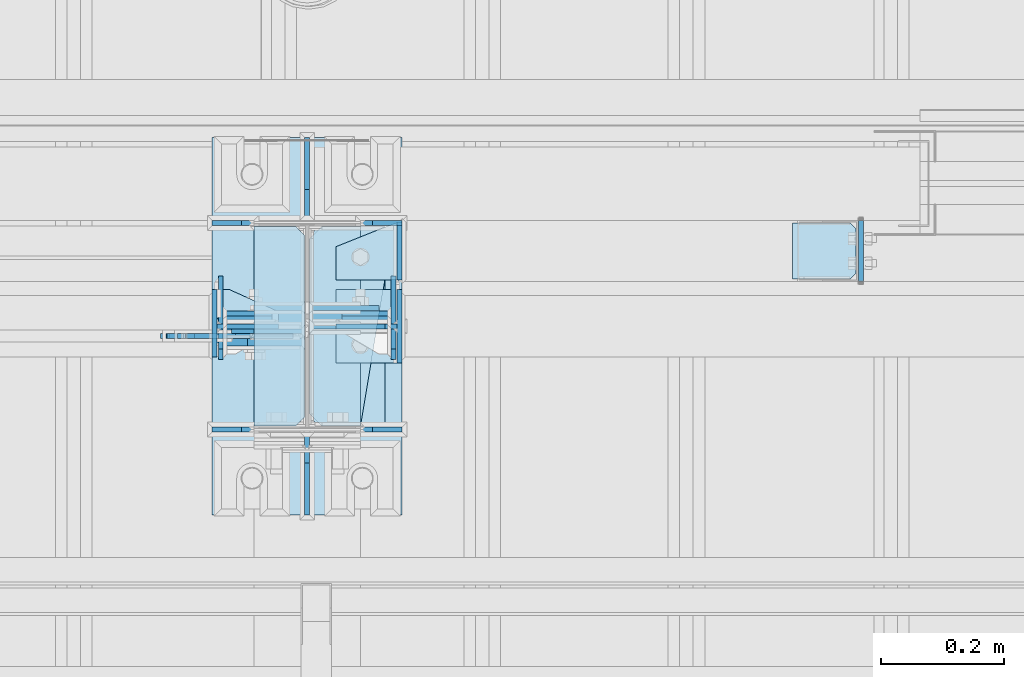
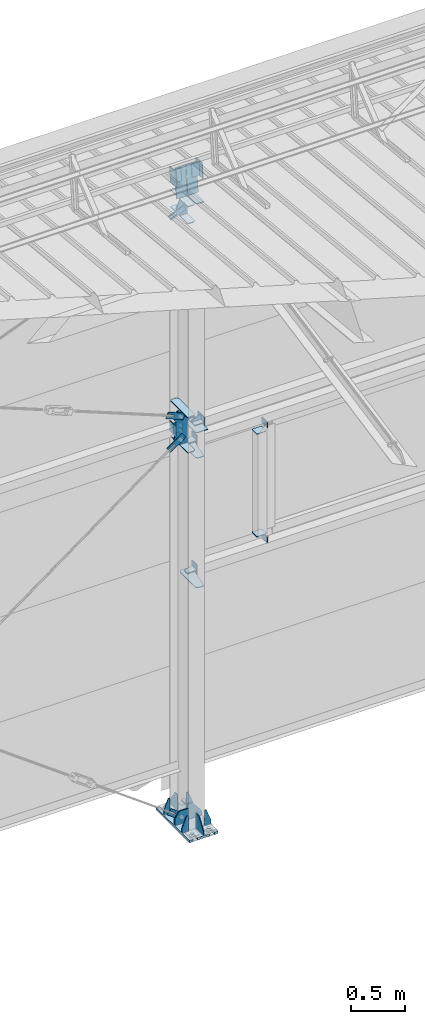
# One storey, part 142 of 709: 43 plates, 4 openings, 12 elements without a shape of their own.
"""IFC4 building model written with IfcOpenShell, lengths in millimetres."""

from ifc_helpers import new_model, si_unit, direction, frame, origin_with_axes, place, context, subcontext, project, spatial, line, arc, indexed_curve, outline, extrude, material, element, aggregate, save


model = new_model("IFC4")

# Units and contexts
model_context = context("Model", 3, precision=0.2, world=origin_with_axes(), true_north=direction((0.0, 1.0)))
body_context = subcontext(model_context, "Body", "Model", "MODEL_VIEW")
ifc_project = project(units=[si_unit("LENGTHUNIT", "METRE", prefix="MILLI"), si_unit("AREAUNIT", "SQUARE_METRE"), si_unit("VOLUMEUNIT", "CUBIC_METRE"), si_unit("MASSUNIT", "GRAM", prefix="KILO"), si_unit("TIMEUNIT", "SECOND"), si_unit("PLANEANGLEUNIT", "RADIAN"), si_unit("SOLIDANGLEUNIT", "STERADIAN"), si_unit("THERMODYNAMICTEMPERATUREUNIT", "DEGREE_CELSIUS"), si_unit("LUMINOUSINTENSITYUNIT", "LUMEN")], contexts=[model_context])

# Site, building, storey
site_placement = place(None, origin_with_axes())
site = spatial("IfcSite", under=ifc_project, at=site_placement, CompositionType="ELEMENT")
building_placement = place(site_placement, origin_with_axes())
building = spatial("IfcBuilding", under=site, at=building_placement, Name="Undefined", CompositionType="ELEMENT")
storey_placement = place(building_placement, origin_with_axes())
storey = spatial("IfcBuildingStorey", under=building, at=storey_placement, Name="Undefined", CompositionType="ELEMENT", Elevation=0.0)

# Assembly, plates
assembly_1_placement = place(storey_placement, frame((34000.0, 21950.0, 2550.0), z_axis=(0.0, 0.0, -1.0), x_axis=(-1.0, 0.0, 0.0)))
assembly_1 = element("IfcElementAssembly", 1, at=assembly_1_placement, inside=storey)
ifc_material = material(Name="C355-6", Category="STEEL")
plate_1_placement = place(assembly_1_placement, frame((5849.0, 47.0, -60.0), z_axis=(-1.0, 0.0, 0.0), x_axis=(0.0, -1.0, 0.0)))
plate_1 = element("IfcPlate", 2, at=plate_1_placement, material=ifc_material, ObjectType="501", context=body_context, shape_type="SolidModel", body=[
    extrude(outline(indexed_curve([(0.0, 0.0), (94.0, 0.0), (94.0, 120.0), (0.0, 120.0)], segments=[line(1, 2, 3, 4, 1)])), frame((0.0, 0.0, 4.0), z_axis=(0.0, 0.0, 1.0), x_axis=(1.0, 0.0, 0.0)), (0.0, 0.0, -1.0), 8.0),
])
plate_2_placement = place(assembly_1_placement, frame((5853.0, 47.0, 0.0), z_axis=(0.0, 0.0, 1.0), x_axis=(0.0, -1.0, 0.0)))
plate_2 = element("IfcPlate", 3, at=plate_2_placement, material=ifc_material, ObjectType="502", context=body_context, shape_type="SolidModel", body=[
    extrude(outline(indexed_curve([(0.0, 0.0), (94.0, 0.0), (94.0, 100.0), (40.0, 100.0), (0.0, 0.0)], segments=[line(1, 2, 3, 4, 5, 1)])), frame((0.0, 0.0, 4.0), z_axis=(0.0, 0.0, 1.0), x_axis=(1.0, 0.0, 0.0)), (0.0, 0.0, -1.0), 8.0),
])
plate_3_placement = place(assembly_1_placement, frame((5096.0, 50.0, -50.0), z_axis=(-1.0, 0.0, 0.0), x_axis=(0.0, 0.0, -1.0)))
plate_3 = element("IfcPlate", 4, at=plate_3_placement, material=ifc_material, ObjectType="509", context=body_context, shape_type="SolidModel", body=[
    extrude(outline(indexed_curve([(0.0, 0.0), (65.0, 0.0), (65.0, 100.0), (0.0, 100.0)], segments=[line(1, 2, 3, 4, 1)])), frame((0.0, 0.0, 4.0), z_axis=(0.0, 0.0, 1.0), x_axis=(1.0, 0.0, 0.0)), (0.0, 0.0, -1.0), 8.0),
])
aggregate(assembly_1, [plate_1, plate_2, plate_3])

assembly_2_placement = place(storey_placement, frame((34000.0, 21950.0, 4020.0), z_axis=(0.0, 0.0, -1.0), x_axis=(-1.0, 0.0, 0.0)))
assembly_2 = element("IfcElementAssembly", 5, at=assembly_2_placement, inside=storey)
plate_4_placement = place(assembly_2_placement, frame((5849.0, 47.0, -60.0), z_axis=(-1.0, 0.0, 0.0), x_axis=(0.0, -1.0, 0.0)))
plate_4 = element("IfcPlate", 6, at=plate_4_placement, material=ifc_material, ObjectType="501", context=body_context, shape_type="SolidModel", body=[
    extrude(outline(indexed_curve([(0.0, 0.0), (94.0, 0.0), (94.0, 120.0), (0.0, 120.0)], segments=[line(1, 2, 3, 4, 1)])), frame((0.0, 0.0, 4.0), z_axis=(0.0, 0.0, 1.0), x_axis=(1.0, 0.0, 0.0)), (0.0, 0.0, -1.0), 8.0),
])
plate_5_placement = place(assembly_2_placement, frame((5853.0, 47.0, 0.0), z_axis=(0.0, 0.0, 1.0), x_axis=(0.0, -1.0, 0.0)))
plate_5 = element("IfcPlate", 7, at=plate_5_placement, material=ifc_material, ObjectType="502", context=body_context, shape_type="SolidModel", body=[
    extrude(outline(indexed_curve([(0.0, 0.0), (94.0, 0.0), (94.0, 100.0), (40.0, 100.0), (0.0, 0.0)], segments=[line(1, 2, 3, 4, 5, 1)])), frame((0.0, 0.0, 4.0), z_axis=(0.0, 0.0, 1.0), x_axis=(1.0, 0.0, 0.0)), (0.0, 0.0, -1.0), 8.0),
])
plate_6_placement = place(assembly_2_placement, frame((5096.0, -50.0, 50.0), z_axis=(-1.0, 0.0, 0.0), x_axis=(0.0, 0.0, 1.0)))
plate_6 = element("IfcPlate", 8, at=plate_6_placement, material=ifc_material, ObjectType="509", context=body_context, shape_type="SolidModel", body=[
    extrude(outline(indexed_curve([(0.0, 0.0), (65.0, 0.0), (65.0, 100.0), (0.0, 100.0)], segments=[line(1, 2, 3, 4, 1)])), frame((0.0, 0.0, 4.0), z_axis=(0.0, 0.0, 1.0), x_axis=(1.0, 0.0, 0.0)), (0.0, 0.0, -1.0), 8.0),
])
aggregate(assembly_2, [plate_4, plate_5, plate_6])

assembly_3_placement = place(storey_placement, frame((28850.0, 21950.0, 2600.0), z_axis=(-1.0, 0.0, 0.0), x_axis=(0.0, 0.0, 1.0)))
assembly_3 = element("IfcElementAssembly", 9, at=assembly_3_placement, inside=storey)
plate_7_placement = place(assembly_3_placement, frame((1267.0, -46.0, -46.0), z_axis=(1.0, 0.0, 0.0), x_axis=(0.0, 1.0, 0.0)))
plate_7 = element("IfcPlate", 10, at=plate_7_placement, material=ifc_material, ObjectType="510", context=body_context, shape_type="SolidModel", body=[
    extrude(outline(indexed_curve([(0.0, 10.0), (10.0, 0.0), (82.0, 0.0), (92.0, 10.0), (92.0, 104.0), (0.0, 104.0)], segments=[line(1, 2, 3, 4, 5, 6, 1)])), frame((0.0, 0.0, 4.0), z_axis=(0.0, 0.0, 1.0), x_axis=(1.0, 0.0, 0.0)), (0.0, 0.0, -1.0), 8.0),
])
plate_8_placement = place(assembly_3_placement, frame((103.0, 46.0, -46.0), z_axis=(-1.0, 0.0, 0.0), x_axis=(0.0, -1.0, 0.0)))
plate_8 = element("IfcPlate", 11, at=plate_8_placement, material=ifc_material, ObjectType="510", context=body_context, shape_type="SolidModel", body=[
    extrude(outline(indexed_curve([(0.0, 10.0), (10.0, 0.0), (82.0, 0.0), (92.0, 10.0), (92.0, 104.0), (0.0, 104.0)], segments=[line(1, 2, 3, 4, 5, 6, 1)])), frame((0.0, 0.0, 4.0), z_axis=(0.0, 0.0, 1.0), x_axis=(1.0, 0.0, 0.0)), (0.0, 0.0, -1.0), 8.0),
])
aggregate(assembly_3, [plate_7, plate_8])

assembly_4_placement = place(storey_placement, frame((34000.0, 21827.0, 4310.0), z_axis=(0.0, 0.0, -1.0), x_axis=(-1.0, 0.0, 0.0)))
assembly_4 = element("IfcElementAssembly", 12, at=assembly_4_placement, inside=storey)
plate_9_placement = place(assembly_4_placement, frame((5953.0, 0.0, -60.0), z_axis=(0.0, -1.0, 0.0), x_axis=(0.0, 0.0, 1.0)))
plate_9 = element("IfcPlate", 13, at=plate_9_placement, material=ifc_material, ObjectType="508", context=body_context, shape_type="SolidModel", body=[
    extrude(outline(indexed_curve([(0.0, 80.0), (36.0, 0.0), (56.0, 0.0), (56.0, 90.0), (46.0, 100.0), (0.0, 100.0)], segments=[line(1, 2, 3, 4, 5, 6, 1)])), frame((0.0, 0.0, 4.0), z_axis=(0.0, 0.0, 1.0), x_axis=(1.0, 0.0, 0.0)), (0.0, 0.0, -1.0), 8.0),
])
plate_10_placement = place(assembly_4_placement, frame((5953.0, -60.0, 0.0), z_axis=(0.0, 0.0, 1.0), x_axis=(0.0, 1.0, 0.0)))
plate_10 = element("IfcPlate", 14, at=plate_10_placement, material=ifc_material, ObjectType="507", context=body_context, shape_type="SolidModel", body=[
    extrude(outline(indexed_curve([(0.0, 0.0), (120.0, 0.0), (120.0, 100.0), (0.0, 100.0)], segments=[line(1, 2, 3, 4, 1)])), frame((0.0, 0.0, 4.0), z_axis=(0.0, 0.0, 1.0), x_axis=(1.0, 0.0, 0.0)), (0.0, 0.0, -1.0), 8.0),
])
plate_11_placement = place(assembly_4_placement, frame((5849.0, -60.0, 60.0), z_axis=(1.0, 0.0, 0.0), x_axis=(0.0, 0.0, -1.0)))
plate_11 = element("IfcPlate", 15, at=plate_11_placement, material=ifc_material, ObjectType="506", context=body_context, shape_type="SolidModel", body=[
    extrude(outline(indexed_curve([(0.0, 0.0), (120.0, 0.0), (120.0, 120.0), (0.0, 120.0)], segments=[line(1, 2, 3, 4, 1)])), frame((0.0, 0.0, 4.0), z_axis=(0.0, 0.0, 1.0), x_axis=(1.0, 0.0, 0.0)), (0.0, 0.0, -1.0), 8.0),
])
aggregate(assembly_4, [plate_9, plate_10, plate_11])

assembly_5_placement = place(storey_placement, frame((28000.0, 21827.0, 4310.0), z_axis=(0.0, 0.0, -1.0), x_axis=(-1.0, 0.0, 0.0)))
assembly_5 = element("IfcElementAssembly", 16, at=assembly_5_placement, inside=storey)
plate_12_placement = place(assembly_5_placement, frame((47.0, 60.0, 0.0), z_axis=(0.0, 0.0, 1.0), x_axis=(0.0, -1.0, 0.0)))
plate_12 = element("IfcPlate", 17, at=plate_12_placement, material=ifc_material, ObjectType="521", context=body_context, shape_type="SolidModel", body=[
    extrude(outline(indexed_curve([(0.0, 80.0), (36.0, 0.0), (56.0, 0.0), (56.0, 90.0), (46.0, 100.0), (0.0, 100.0)], segments=[line(1, 2, 3, 4, 5, 6, 1)])), frame((0.0, 0.0, 4.0), z_axis=(0.0, 0.0, 1.0), x_axis=(1.0, 0.0, 0.0)), (0.0, 0.0, -1.0), 8.0),
])
plate_13_placement = place(assembly_5_placement, frame((47.0, 0.0, 60.0), z_axis=(0.0, -1.0, 0.0), x_axis=(0.0, 0.0, -1.0)))
plate_13 = element("IfcPlate", 18, at=plate_13_placement, material=ifc_material, ObjectType="520", context=body_context, shape_type="SolidModel", body=[
    extrude(outline(indexed_curve([(0.0, 0.0), (120.0, 0.0), (120.0, 100.0), (0.0, 100.0)], segments=[line(1, 2, 3, 4, 1)])), frame((0.0, 0.0, 4.0), z_axis=(0.0, 0.0, 1.0), x_axis=(1.0, 0.0, 0.0)), (0.0, 0.0, -1.0), 8.0),
])
plate_14_placement = place(assembly_5_placement, frame((151.0, -50.0, 60.0), z_axis=(-1.0, 0.0, 0.0), x_axis=(0.0, 1.0, 0.0)))
plate_14 = element("IfcPlate", 19, at=plate_14_placement, material=ifc_material, ObjectType="519", context=body_context, shape_type="SolidModel", body=[
    extrude(outline(indexed_curve([(0.0, 0.0), (110.0, 0.0), (110.0, 120.0), (0.0, 120.0)], segments=[line(1, 2, 3, 4, 1)])), frame((0.0, 0.0, 4.0), z_axis=(0.0, 0.0, 1.0), x_axis=(1.0, 0.0, 0.0)), (0.0, 0.0, -1.0), 8.0),
])
aggregate(assembly_5, [plate_12, plate_13, plate_14])

# Assembly, plate
assembly_6_placement = place(storey_placement, frame((28000.0, 21811.0, -155.0), z_axis=(0.0, 1.0, 0.0), x_axis=(-0.8064830392, 0.0, 0.5912572262)))
assembly_6 = element("IfcElementAssembly", 20, at=assembly_6_placement, inside=storey)
plate_15_placement = place(assembly_6_placement, frame((254.17845, 11.0, 0.0), z_axis=(0.0, 0.0, -1.0), x_axis=(-1.0, 0.0, 0.0)))
plate_15 = element("IfcPlate", 21, at=plate_15_placement, material=ifc_material, ObjectType="490", context=body_context, shape_type="SolidModel", body=[
    extrude(outline(indexed_curve([(0.0, 0.0), (80.0, 0.0), (80.0, -22.0), (0.0, -22.0), (0.0, -46.0), (200.0, -46.0), (200.0, 24.0), (0.0, 24.0)], segments=[line(1, 2, 3, 4, 5, 6, 7, 8, 1)])), frame((0.0, 0.0, 4.0), z_axis=(0.0, 0.0, 1.0), x_axis=(1.0, 0.0, 0.0)), (0.0, 0.0, -1.0), 8.0),
])
aggregate(assembly_6, [plate_15])

assembly_7_placement = place(storey_placement, frame((27913.0, 21811.0, 4180.0), z_axis=(0.0, 1.0, 0.0), x_axis=(-0.8064830392, 0.0, -0.5912572261)))
assembly_7 = element("IfcElementAssembly", 22, at=assembly_7_placement, inside=storey)
plate_16_placement = place(assembly_7_placement, frame((150.0, -35.0, 0.0), z_axis=(0.0, 0.0, -1.0), x_axis=(-1.0, 0.0, 0.0)))
plate_16 = element("IfcPlate", 23, at=plate_16_placement, material=ifc_material, ObjectType="525", context=body_context, shape_type="SolidModel", body=[
    extrude(outline(indexed_curve([(0.0, 0.0), (200.0, 0.0), (200.0, 70.0), (0.0, 70.0), (0.0, 46.0), (80.0, 46.0), (80.0, 24.0), (0.0, 24.0)], segments=[line(1, 2, 3, 4, 5, 6, 7, 8, 1)])), frame((0.0, 0.0, 4.0), z_axis=(0.0, 0.0, 1.0), x_axis=(1.0, 0.0, 0.0)), (0.0, 0.0, -1.0), 8.0),
])
aggregate(assembly_7, [plate_16])

assembly_8_placement = place(storey_placement, frame((27913.0, 21811.0, 4440.0), z_axis=(0.0, 1.0, 0.0), x_axis=(-0.9286065, 0.0, 0.371065989)))
assembly_8 = element("IfcElementAssembly", 24, at=assembly_8_placement, inside=storey)
plate_17_placement = place(assembly_8_placement, frame((150.0, -35.0, 0.0), z_axis=(0.0, 0.0, -1.0), x_axis=(-1.0, 0.0, 0.0)))
plate_17 = element("IfcPlate", 25, at=plate_17_placement, material=ifc_material, ObjectType="525", context=body_context, shape_type="SolidModel", body=[
    extrude(outline(indexed_curve([(0.0, 0.0), (200.0, 0.0), (200.0, 70.0), (0.0, 70.0), (0.0, 46.0), (80.0, 46.0), (80.0, 24.0), (0.0, 24.0)], segments=[line(1, 2, 3, 4, 5, 6, 7, 8, 1)])), frame((0.0, 0.0, 4.0), z_axis=(0.0, 0.0, 1.0), x_axis=(1.0, 0.0, 0.0)), (0.0, 0.0, -1.0), 8.0),
])
aggregate(assembly_8, [plate_17])

assembly_9_placement = place(storey_placement, frame((27913.0, 21811.0, 6768.03718), z_axis=(0.0, 1.0, 0.0), x_axis=(-0.9286065, 0.0, -0.371065989)))
assembly_9 = element("IfcElementAssembly", 26, at=assembly_9_placement, inside=storey)
plate_18_placement = place(assembly_9_placement, frame((123.06736, 11.0, 0.0), z_axis=(0.0, 0.0, -1.0), x_axis=(-1.0, 0.0, 0.0)))
plate_18 = element("IfcPlate", 27, at=plate_18_placement, material=ifc_material, ObjectType="556", context=body_context, shape_type="SolidModel", body=[
    extrude(outline(indexed_curve([(0.0, 0.0), (80.0, 0.0), (80.0, -22.0), (0.0, -22.0), (0.0, -41.0), (180.0, -41.0), (180.0, 19.0), (0.0, 19.0)], segments=[line(1, 2, 3, 4, 5, 6, 7, 8, 1)])), frame((0.0, 0.0, 4.0), z_axis=(0.0, 0.0, 1.0), x_axis=(1.0, 0.0, 0.0)), (0.0, 0.0, -1.0), 8.0),
])
aggregate(assembly_9, [plate_18])

# Assembly, plates, voiding features
assembly_10_placement = place(storey_placement, frame((28000.0, 21827.0, -200.0), z_axis=(-1.0, 0.0, 0.0), x_axis=(0.0, 0.0, 1.0)))
assembly_10 = element("IfcElementAssembly", 28, at=assembly_10_placement, inside=storey)
plate_19_placement = place(assembly_10_placement, frame((7434.21546, 30.02526, -3.0), z_axis=(-0.099503719, 0.9950371902, 0.0), x_axis=(0.0, 0.0, -1.0)))
plate_19 = element("IfcPlate", 29, at=plate_19_placement, material=ifc_material, ObjectType="595", context=body_context, shape_type="SolidModel", body=[
    extrude(outline(indexed_curve([(0.0, 0.0), (114.0, 0.0), (114.0, 333.33554), (0.0, 333.33554)], segments=[line(1, 2, 3, 4, 1)])), frame((0.0, 0.0, 4.0), z_axis=(0.0, 0.0, 1.0), x_axis=(1.0, 0.0, 0.0)), (0.0, 0.0, -1.0), 8.0),
])
plate_20_placement = place(assembly_10_placement, frame((7434.21546, 30.02526, 3.0), z_axis=(0.099503719, -0.9950371902, 0.0), x_axis=(0.0, 0.0, 1.0)))
plate_20 = element("IfcPlate", 30, at=plate_20_placement, material=ifc_material, ObjectType="595", context=body_context, shape_type="SolidModel", body=[
    extrude(outline(indexed_curve([(0.0, 0.0), (114.0, 0.0), (114.0, 332.53554), (0.0, 332.53554)], segments=[line(1, 2, 3, 4, 1)])), frame((0.0, 0.0, 4.0), z_axis=(0.0, 0.0, 1.0), x_axis=(1.0, 0.0, 0.0)), (0.0, 0.0, -1.0), 8.0),
])
plate_21_placement = place(assembly_10_placement, frame((25.0, 173.0, 0.0), z_axis=(0.0, 0.0, -1.0), x_axis=(0.0, 1.0, 0.0)))
plate_21 = element("IfcPlate", 31, at=plate_21_placement, material=ifc_material, ObjectType="418", context=body_context, shape_type="SolidModel", body=[
    extrude(outline(indexed_curve([(0.0, 0.0), (135.0, 0.0), (135.0, 50.0), (50.0, 175.0), (0.0, 175.0)], segments=[line(1, 2, 3, 4, 5, 1)])), frame((0.0, 0.0, 4.0), z_axis=(0.0, 0.0, 1.0), x_axis=(1.0, 0.0, 0.0)), (0.0, 0.0, -1.0), 8.0),
])
plate_22_placement = place(assembly_10_placement, frame((25.0, -173.0, 0.0), z_axis=(0.0, 0.0, 1.0), x_axis=(0.0, -1.0, 0.0)))
plate_22 = element("IfcPlate", 32, at=plate_22_placement, material=ifc_material, ObjectType="418", context=body_context, shape_type="SolidModel", body=[
    extrude(outline(indexed_curve([(0.0, 0.0), (135.0, 0.0), (135.0, 50.0), (50.0, 175.0), (0.0, 175.0)], segments=[line(1, 2, 3, 4, 5, 1)])), frame((0.0, 0.0, 4.0), z_axis=(0.0, 0.0, 1.0), x_axis=(1.0, 0.0, 0.0)), (0.0, 0.0, -1.0), 8.0),
])
plate_23_placement = place(assembly_10_placement, frame((25.0, 168.5, -87.0), z_axis=(0.0, -1.0, 0.0), x_axis=(0.0, 0.0, -1.0)))
plate_23 = element("IfcPlate", 33, at=plate_23_placement, material=ifc_material, ObjectType="419", context=body_context, shape_type="SolidModel", body=[
    extrude(outline(indexed_curve([(0.0, 0.0), (68.0, 0.0), (68.0, 50.0), (20.0, 175.0), (0.0, 175.0)], segments=[line(1, 2, 3, 4, 5, 1)])), frame((0.0, 0.0, 4.0), z_axis=(0.0, 0.0, 1.0), x_axis=(1.0, 0.0, 0.0)), (0.0, 0.0, -1.0), 8.0),
])
plate_24_placement = place(assembly_10_placement, frame((25.0, -168.5, -87.0), z_axis=(0.0, -1.0, 0.0), x_axis=(0.0, 0.0, -1.0)))
plate_24 = element("IfcPlate", 34, at=plate_24_placement, material=ifc_material, ObjectType="419", context=body_context, shape_type="SolidModel", body=[
    extrude(outline(indexed_curve([(0.0, 0.0), (68.0, 0.0), (68.0, 50.0), (20.0, 175.0), (0.0, 175.0)], segments=[line(1, 2, 3, 4, 5, 1)])), frame((0.0, 0.0, 4.0), z_axis=(0.0, 0.0, 1.0), x_axis=(1.0, 0.0, 0.0)), (0.0, 0.0, -1.0), 8.0),
])
plate_25_placement = place(assembly_10_placement, frame((25.0, 168.5, 87.0), z_axis=(0.0, 1.0, 0.0), x_axis=(0.0, 0.0, 1.0)))
plate_25 = element("IfcPlate", 35, at=plate_25_placement, material=ifc_material, ObjectType="419", context=body_context, shape_type="SolidModel", body=[
    extrude(outline(indexed_curve([(0.0, 0.0), (68.0, 0.0), (68.0, 50.0), (20.0, 175.0), (0.0, 175.0)], segments=[line(1, 2, 3, 4, 5, 1)])), frame((0.0, 0.0, 4.0), z_axis=(0.0, 0.0, 1.0), x_axis=(1.0, 0.0, 0.0)), (0.0, 0.0, -1.0), 8.0),
])
plate_26_placement = place(assembly_10_placement, frame((25.0, -168.5, 87.0), z_axis=(0.0, 1.0, 0.0), x_axis=(0.0, 0.0, 1.0)))
plate_26 = element("IfcPlate", 36, at=plate_26_placement, material=ifc_material, ObjectType="419", context=body_context, shape_type="SolidModel", body=[
    extrude(outline(indexed_curve([(0.0, 0.0), (68.0, 0.0), (68.0, 50.0), (20.0, 175.0), (0.0, 175.0)], segments=[line(1, 2, 3, 4, 5, 1)])), frame((0.0, 0.0, 4.0), z_axis=(0.0, 0.0, 1.0), x_axis=(1.0, 0.0, 0.0)), (0.0, 0.0, -1.0), 8.0),
])
plate_27_placement = place(assembly_10_placement, frame((12.5, -308.0, 155.0), z_axis=(1.0, 0.0, 0.0), x_axis=(0.0, 0.0, -1.0)))
plate_27 = element("IfcPlate", 37, at=plate_27_placement, material=ifc_material, context=body_context, shape_type="SolidModel", body=[
    extrude(outline(indexed_curve([(0.0, 0.0), (310.0, 0.0), (310.0, 616.0), (0.0, 616.0)], segments=[line(1, 2, 3, 4, 1)])), frame((0.0, 0.0, 12.5), z_axis=(0.0, 0.0, 1.0), x_axis=(1.0, 0.0, 0.0)), (0.0, 0.0, -1.0), 25.0),
])
voiding_feature_1_placement = place(plate_27_placement, frame((40.0, 616.0, 0.0), z_axis=(0.0, 0.0, -1.0), x_axis=(1.0, 0.0, 0.0)))
element("IfcVoidingFeature", 38, at=voiding_feature_1_placement, cuts=plate_27, PredefinedType="HOLE", context=body_context, shape_type="SolidModel", body=[
    extrude(outline(indexed_curve([(0.0, 0.0), (50.0, 0.0), (50.0, 60.0), (42.67767, 77.67767), (25.0, 85.0), (25.0, 85.0), (7.32233, 77.67767), (0.0, 60.0)], segments=[line(1, 2, 3), arc(3, 4, 5), line(5, 6), arc(6, 7, 8), line(8, 1)])), frame((0.0, 0.0, 12.5), z_axis=(0.0, 0.0, 1.0), x_axis=(1.0, 0.0, 0.0)), (0.0, 0.0, -1.0), 25.0),
])
voiding_feature_2_placement = place(plate_27_placement, frame((40.0, 0.0, 0.0), z_axis=(0.0, 0.0, 1.0), x_axis=(1.0, 0.0, 0.0)))
element("IfcVoidingFeature", 39, at=voiding_feature_2_placement, cuts=plate_27, PredefinedType="HOLE", context=body_context, shape_type="SolidModel", body=[
    extrude(outline(indexed_curve([(0.0, 0.0), (50.0, 0.0), (50.0, 60.0), (42.67767, 77.67767), (25.0, 85.0), (25.0, 85.0), (7.32233, 77.67767), (0.0, 60.0)], segments=[line(1, 2, 3), arc(3, 4, 5), line(5, 6), arc(6, 7, 8), line(8, 1)])), frame((0.0, 0.0, 12.5), z_axis=(0.0, 0.0, 1.0), x_axis=(1.0, 0.0, 0.0)), (0.0, 0.0, -1.0), 25.0),
])
voiding_feature_3_placement = place(plate_27_placement, frame((270.0, 616.0, 0.0), z_axis=(0.0, 0.0, 1.0), x_axis=(-1.0, 0.0, 0.0)))
element("IfcVoidingFeature", 40, at=voiding_feature_3_placement, cuts=plate_27, PredefinedType="HOLE", context=body_context, shape_type="SolidModel", body=[
    extrude(outline(indexed_curve([(0.0, 0.0), (50.0, 0.0), (50.0, 60.0), (42.67767, 77.67767), (25.0, 85.0), (25.0, 85.0), (7.32233, 77.67767), (0.0, 60.0)], segments=[line(1, 2, 3), arc(3, 4, 5), line(5, 6), arc(6, 7, 8), line(8, 1)])), frame((0.0, 0.0, 12.5), z_axis=(0.0, 0.0, 1.0), x_axis=(1.0, 0.0, 0.0)), (0.0, 0.0, -1.0), 25.0),
])
voiding_feature_4_placement = place(plate_27_placement, frame((270.0, 0.0, 0.0), z_axis=(0.0, 0.0, -1.0), x_axis=(-1.0, 0.0, 0.0)))
element("IfcVoidingFeature", 41, at=voiding_feature_4_placement, cuts=plate_27, PredefinedType="HOLE", context=body_context, shape_type="SolidModel", body=[
    extrude(outline(indexed_curve([(0.0, 0.0), (50.0, 0.0), (50.0, 60.0), (42.67767, 77.67767), (25.0, 85.0), (25.0, 85.0), (7.32233, 77.67767), (0.0, 60.0)], segments=[line(1, 2, 3), arc(3, 4, 5), line(5, 6), arc(6, 7, 8), line(8, 1)])), frame((0.0, 0.0, 12.5), z_axis=(0.0, 0.0, 1.0), x_axis=(1.0, 0.0, 0.0)), (0.0, 0.0, -1.0), 25.0),
])
plate_28_placement = place(assembly_10_placement, frame((25.0, 0.0, -3.0), z_axis=(0.0, -1.0, 0.0), x_axis=(0.0, 0.0, -1.0)))
plate_28 = element("IfcPlate", 42, at=plate_28_placement, material=ifc_material, ObjectType="417", context=body_context, shape_type="SolidModel", body=[
    extrude(outline(indexed_curve([(0.0, 0.0), (152.0, 0.0), (152.0, 50.0), (50.0, 175.0), (0.0, 175.0)], segments=[line(1, 2, 3, 4, 5, 1)])), frame((0.0, 0.0, 4.0), z_axis=(0.0, 0.0, 1.0), x_axis=(1.0, 0.0, 0.0)), (0.0, 0.0, -1.0), 8.0),
])
plate_29_placement = place(assembly_10_placement, frame((7097.93718, -163.0, -87.0), z_axis=(-1.0, 0.0, 0.0), x_axis=(0.0, 0.0, 1.0)))
plate_29 = element("IfcPlate", 43, at=plate_29_placement, material=ifc_material, ObjectType="461", context=body_context, shape_type="SolidModel", body=[
    extrude(outline(indexed_curve([(0.0, 0.0), (68.0, 0.0), (83.0, 15.0), (83.0, 311.0), (68.0, 326.0), (0.0, 326.0)], segments=[line(1, 2, 3, 4, 5, 6, 1)])), frame((0.0, 0.0, 4.0), z_axis=(0.0, 0.0, 1.0), x_axis=(1.0, 0.0, 0.0)), (0.0, 0.0, -1.0), 8.0),
])
plate_30_placement = place(assembly_10_placement, frame((7097.93718, 163.0, 87.0), z_axis=(-1.0, 0.0, 0.0), x_axis=(0.0, 0.0, -1.0)))
plate_30 = element("IfcPlate", 44, at=plate_30_placement, material=ifc_material, ObjectType="461", context=body_context, shape_type="SolidModel", body=[
    extrude(outline(indexed_curve([(0.0, 0.0), (68.0, 0.0), (83.0, 15.0), (83.0, 311.0), (68.0, 326.0), (0.0, 326.0)], segments=[line(1, 2, 3, 4, 5, 6, 1)])), frame((0.0, 0.0, 4.0), z_axis=(0.0, 0.0, 1.0), x_axis=(1.0, 0.0, 0.0)), (0.0, 0.0, -1.0), 8.0),
])
plate_31_placement = place(assembly_10_placement, frame((6906.03718, 163.0, 87.0), z_axis=(-1.0, 0.0, 0.0), x_axis=(0.0, 0.0, -1.0)))
plate_31 = element("IfcPlate", 45, at=plate_31_placement, material=ifc_material, ObjectType="461", context=body_context, shape_type="SolidModel", body=[
    extrude(outline(indexed_curve([(0.0, 0.0), (68.0, 0.0), (83.0, 15.0), (83.0, 311.0), (68.0, 326.0), (0.0, 326.0)], segments=[line(1, 2, 3, 4, 5, 6, 1)])), frame((0.0, 0.0, 4.0), z_axis=(0.0, 0.0, 1.0), x_axis=(1.0, 0.0, 0.0)), (0.0, 0.0, -1.0), 8.0),
])
plate_32_placement = place(assembly_10_placement, frame((2742.0, -163.0, -4.0), z_axis=(1.0, 0.0, 0.0), x_axis=(0.0, 0.0, -1.0)))
plate_32 = element("IfcPlate", 46, at=plate_32_placement, material=ifc_material, ObjectType="543", context=body_context, shape_type="SolidModel", body=[
    extrude(outline(indexed_curve([(0.0, 20.0), (20.0, 0.0), (83.0, 0.0), (123.0, 240.0), (123.0, 326.0), (20.0, 326.0), (0.0, 306.0)], segments=[line(1, 2, 3, 4, 5, 6, 7, 1)])), frame((0.0, 0.0, 4.0), z_axis=(0.0, 0.0, 1.0), x_axis=(1.0, 0.0, 0.0)), (0.0, 0.0, -1.0), 8.0),
])
plate_33_placement = place(assembly_10_placement, frame((4212.0, -163.0, -4.0), z_axis=(1.0, 0.0, 0.0), x_axis=(0.0, 0.0, -1.0)))
plate_33 = element("IfcPlate", 47, at=plate_33_placement, material=ifc_material, ObjectType="543", context=body_context, shape_type="SolidModel", body=[
    extrude(outline(indexed_curve([(0.0, 20.0), (20.0, 0.0), (83.0, 0.0), (123.0, 240.0), (123.0, 326.0), (20.0, 326.0), (0.0, 306.0)], segments=[line(1, 2, 3, 4, 5, 6, 7, 1)])), frame((0.0, 0.0, 4.0), z_axis=(0.0, 0.0, 1.0), x_axis=(1.0, 0.0, 0.0)), (0.0, 0.0, -1.0), 8.0),
])
plate_34_placement = place(assembly_10_placement, frame((4502.0, -163.0, -127.0), z_axis=(-1.0, 0.0, 0.0), x_axis=(0.0, 0.0, 1.0)))
plate_34 = element("IfcPlate", 48, at=plate_34_placement, material=ifc_material, ObjectType="547", context=body_context, shape_type="SolidModel", body=[
    extrude(outline(indexed_curve([(0.0, 0.0), (108.0, 0.0), (123.0, 15.0), (123.0, 311.0), (108.0, 326.0), (0.0, 326.0)], segments=[line(1, 2, 3, 4, 5, 6, 1)])), frame((0.0, 0.0, 4.0), z_axis=(0.0, 0.0, 1.0), x_axis=(1.0, 0.0, 0.0)), (0.0, 0.0, -1.0), 8.0),
])
plate_35_placement = place(assembly_10_placement, frame((99.86739, -26.0, 150.94888), z_axis=(0.0, 1.0, 0.0), x_axis=(0.8064830392, 0.0, -0.5912572261)))
plate_35 = element("IfcPlate", 49, at=plate_35_placement, material=ifc_material, ObjectType="551", context=body_context, shape_type="SolidModel", body=[
    extrude(outline(indexed_curve([(0.0, 0.0), (90.0, 0.0), (146.01319, 76.40276), (39.19381, 154.71529), (18.22771, 151.4869), (-60.37928, 44.26588)], segments=[line(1, 2, 3, 4, 5, 6, 1)])), frame((0.0, 0.0, 6.0), z_axis=(0.0, 0.0, 1.0), x_axis=(1.0, 0.0, 0.0)), (0.0, 0.0, -1.0), 12.0),
])
plate_36_placement = place(assembly_10_placement, frame((4700.34059, -10.0, 116.73236), z_axis=(0.0, -1.0, 0.0), x_axis=(-0.9286065, 0.0, 0.371065989)))
plate_36 = element("IfcPlate", 50, at=plate_36_placement, material=ifc_material, ObjectType="552", context=body_context, shape_type="SolidModel", body=[
    extrude(outline(indexed_curve([(0.0, 0.0), (90.0, 0.0), (115.55903, 35.1197), (245.56394, 87.06894), (305.02493, 81.82799), (352.68082, 158.17533), (321.98714, 234.98741), (302.49206, 243.35051), (-28.27311, 111.17859), (-36.63622, 91.68351)], segments=[line(1, 2, 3, 4, 5, 6, 7, 8, 9, 10, 1)])), frame((0.0, 0.0, 6.0), z_axis=(0.0, 0.0, 1.0), x_axis=(1.0, 0.0, 0.0)), (0.0, 0.0, -1.0), 12.0),
])
plate_37_placement = place(assembly_10_placement, frame((4706.34059, 163.0, 87.0), z_axis=(-1.0, 0.0, 0.0), x_axis=(0.0, 0.0, -1.0)))
plate_37 = element("IfcPlate", 51, at=plate_37_placement, material=ifc_material, ObjectType="553", context=body_context, shape_type="SolidModel", body=[
    extrude(outline(indexed_curve([(0.0, 0.0), (68.0, 0.0), (83.0, 15.0), (83.0, 311.0), (68.0, 326.0), (0.0, 326.0)], segments=[line(1, 2, 3, 4, 5, 6, 1)])), frame((0.0, 0.0, 6.0), z_axis=(0.0, 0.0, 1.0), x_axis=(1.0, 0.0, 0.0)), (0.0, 0.0, -1.0), 12.0),
])
plate_38_placement = place(assembly_10_placement, frame((4308.14541, 163.0, 87.0), z_axis=(-1.0, 0.0, 0.0), x_axis=(0.0, 0.0, -1.0)))
plate_38 = element("IfcPlate", 52, at=plate_38_placement, material=ifc_material, ObjectType="554", context=body_context, shape_type="SolidModel", body=[
    extrude(outline(indexed_curve([(0.0, 0.0), (68.0, 0.0), (83.0, 15.0), (83.0, 311.0), (68.0, 326.0), (0.0, 326.0)], segments=[line(1, 2, 3, 4, 5, 6, 1)])), frame((0.0, 0.0, 4.0), z_axis=(0.0, 0.0, 1.0), x_axis=(1.0, 0.0, 0.0)), (0.0, 0.0, -1.0), 8.0),
])
plate_39_placement = place(assembly_10_placement, frame((6931.61775, -8.00694, 97.28783), z_axis=(-5.519e-06, 0.9999998141, -0.00060979), x_axis=(0.9286064751, 0.000231397, 0.3710659791)))
plate_39 = element("IfcPlate", 53, at=plate_39_placement, material=ifc_material, Name="PLATE", ObjectType="555", context=body_context, shape_type="SolidModel", body=[
    extrude(outline(indexed_curve([(0.0, 0.0), (70.0, 0.0), (146.9134, 69.78458), (115.74386, 147.78751), (-55.02687, 79.54846), (-23.23974, 0.0)], segments=[line(1, 2, 3, 4, 5, 6, 1)])), frame((0.0, 0.0, 4.0), z_axis=(0.0, 0.0, 1.0), x_axis=(1.0, 0.0, 0.0)), (0.0, 0.0, -1.0), 8.0),
])
aggregate(assembly_10, [plate_19, plate_20, plate_21, plate_22, plate_23, plate_24, plate_25, plate_26, plate_27, plate_28, plate_29, plate_30, plate_31, plate_32, plate_33, plate_34, plate_35, plate_36, plate_37, plate_38, plate_39])

# Assembly, plates
assembly_11_placement = place(storey_placement, frame((28000.0, 21841.04467, 7154.40952), z_axis=(0.0, -0.9950371902, 0.099503719), x_axis=(-1.0, 0.0, 0.0)))
assembly_11 = element("IfcElementAssembly", 54, at=assembly_11_placement, inside=storey)
plate_40_placement = place(assembly_11_placement, frame((141.0, -87.0, -60.0), z_axis=(-1.0, 0.0, 0.0), x_axis=(0.0, 0.0, 1.0)))
plate_40 = element("IfcPlate", 55, at=plate_40_placement, material=ifc_material, ObjectType="596", context=body_context, shape_type="SolidModel", body=[
    extrude(outline(indexed_curve([(0.0, 0.0), (120.0, 0.0), (120.0, 174.0), (0.0, 174.0)], segments=[line(1, 2, 3, 4, 1)])), frame((0.0, 0.0, 4.0), z_axis=(0.0, 0.0, 1.0), x_axis=(1.0, 0.0, 0.0)), (0.0, 0.0, -1.0), 8.0),
])
plate_41_placement = place(assembly_11_placement, frame((57.0, -72.0, 0.0), z_axis=(0.0, 0.0, 1.0), x_axis=(1.0, 0.0, 0.0)))
plate_41 = element("IfcPlate", 56, at=plate_41_placement, material=ifc_material, ObjectType="597", context=body_context, shape_type="SolidModel", body=[
    extrude(outline(indexed_curve([(0.0, 0.0), (80.0, 0.0), (80.0, 144.0), (0.0, 144.0)], segments=[line(1, 2, 3, 4, 1)])), frame((0.0, 0.0, 4.0), z_axis=(0.0, 0.0, 1.0), x_axis=(1.0, 0.0, 0.0)), (0.0, 0.0, -1.0), 8.0),
])
aggregate(assembly_11, [plate_40, plate_41])

assembly_12_placement = place(storey_placement, frame((34000.0, 21841.04467, 7154.40952), z_axis=(0.0, -0.9950371902, 0.099503719), x_axis=(-1.0, 0.0, 0.0)))
assembly_12 = element("IfcElementAssembly", 57, at=assembly_12_placement, inside=storey)
plate_42_placement = place(assembly_12_placement, frame((5943.0, 72.0, 0.0), z_axis=(0.0, 0.0, 1.0), x_axis=(-1.0, 0.0, 0.0)))
plate_42 = element("IfcPlate", 58, at=plate_42_placement, material=ifc_material, ObjectType="597", context=body_context, shape_type="SolidModel", body=[
    extrude(outline(indexed_curve([(0.0, 0.0), (80.0, 0.0), (80.0, 144.0), (0.0, 144.0)], segments=[line(1, 2, 3, 4, 1)])), frame((0.0, 0.0, 4.0), z_axis=(0.0, 0.0, 1.0), x_axis=(1.0, 0.0, 0.0)), (0.0, 0.0, -1.0), 8.0),
])
plate_43_placement = place(assembly_12_placement, frame((5859.0, -87.0, 60.0), z_axis=(1.0, 0.0, 0.0), x_axis=(0.0, 0.0, -1.0)))
plate_43 = element("IfcPlate", 59, at=plate_43_placement, material=ifc_material, ObjectType="596", context=body_context, shape_type="SolidModel", body=[
    extrude(outline(indexed_curve([(0.0, 0.0), (120.0, 0.0), (120.0, 174.0), (0.0, 174.0)], segments=[line(1, 2, 3, 4, 1)])), frame((0.0, 0.0, 4.0), z_axis=(0.0, 0.0, 1.0), x_axis=(1.0, 0.0, 0.0)), (0.0, 0.0, -1.0), 8.0),
])
aggregate(assembly_12, [plate_42, plate_43])

save(model, "model.ifc")
